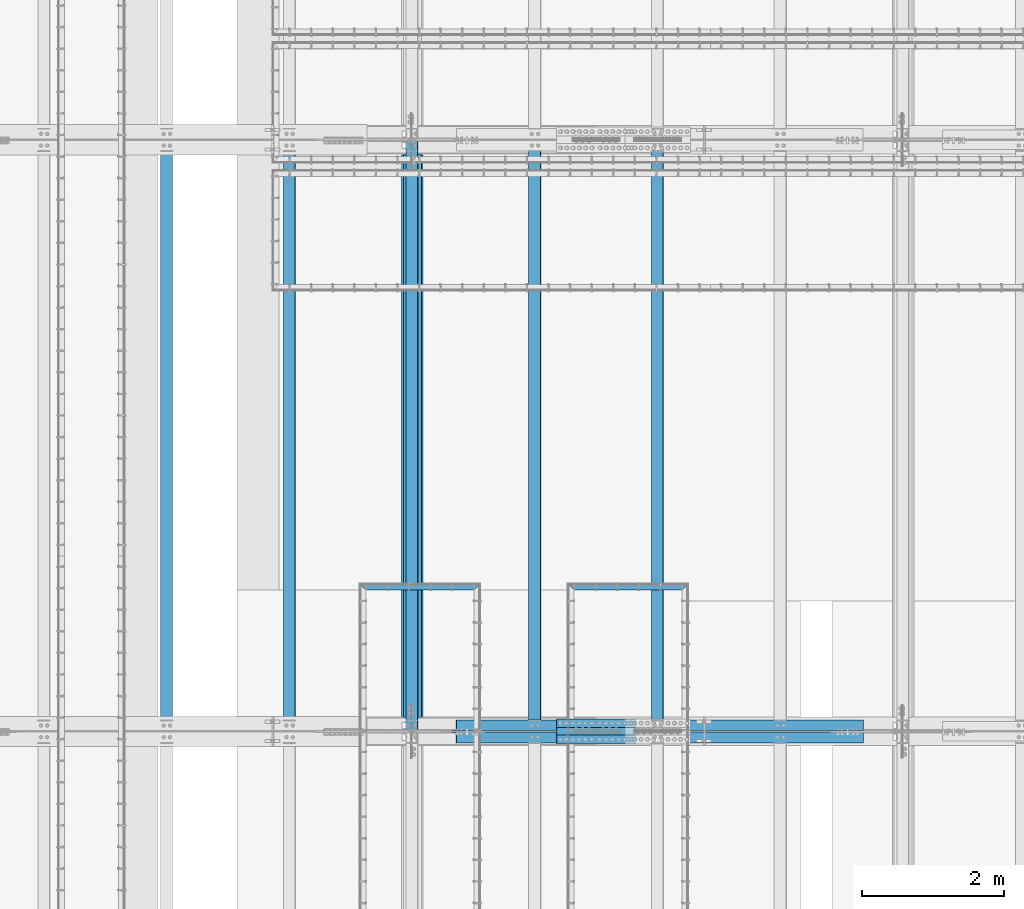
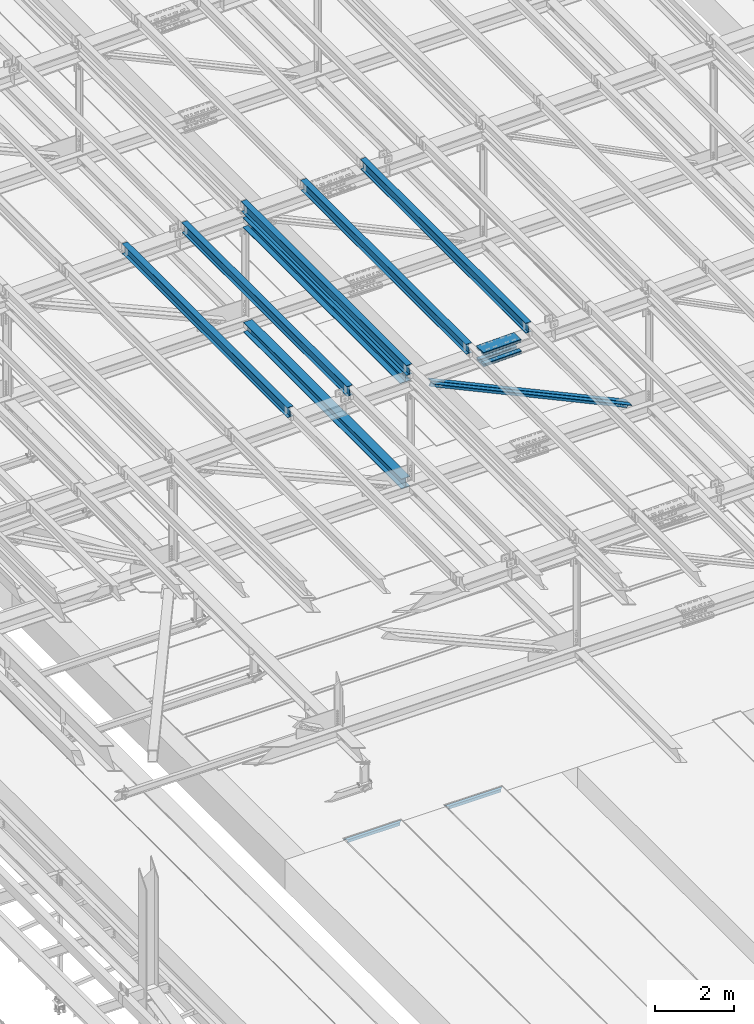
# One storey, part 1844 of 3843: 15 beams, 2 members, 12 elements without a shape of their own.
"""IFC2X3 building model written with IfcOpenShell, lengths in millimetres."""

import ifcopenshell
import ifcopenshell.guid

model = None  # the IFC model being written
_history = None  # IfcOwnerHistory: only IFC2X3 demands one
_inside = {}  # id of a spatial element -> (the spatial element, [elements in it])
_under = {}  # id of a project, library or spatial element -> (it, [spatial elements below it])
_declared = {}  # id of a project -> (the project, [libraries it declares])
_typed = {}  # id of a type object -> (the type object, [elements of that type])
_made_of = {}  # id of a material, layer set ... -> (it, [elements and type objects made of it])


def new_model(schema):
    """Start an empty IFC model of exactly this schema.

    Asked for "IFC4X3", IfcOpenShell would pick the latest addendum, in which some entities
    have other attributes; the version numbers below select the first issue.
    IFC2X3 requires an IfcOwnerHistory on every rooted entity: one is made here for all.
    """
    global model, _history
    if schema == "IFC4X3":
        model = ifcopenshell.file(schema_version=(4, 3, 0, 0))
    else:
        model = ifcopenshell.file(schema=schema)
    _inside.clear()
    _under.clear()
    _declared.clear()
    _typed.clear()
    _made_of.clear()
    _history = None
    if model.schema == "IFC2X3":
        org = make("IfcOrganization", Name="unknown")
        user = make(
            "IfcPersonAndOrganization",
            ThePerson=make("IfcPerson", FamilyName="unknown"),
            TheOrganization=org,
        )
        app = make(
            "IfcApplication",
            ApplicationDeveloper=org,
            Version="unknown",
            ApplicationFullName="unknown",
            ApplicationIdentifier="unknown",
        )
        _history = make(
            "IfcOwnerHistory",
            OwningUser=user,
            OwningApplication=app,
            ChangeAction="ADDED",
            CreationDate=0,
        )
    return model


def make(cls, **values):
    """One entity of the class cls with the attributes given. An attribute that is None is left unset."""
    return model.create_entity(
        cls, **{name: value for name, value in values.items() if value is not None}
    )


def rooted(cls, **values):
    """An entity with a GlobalId (a new one), such as an element, a storey or a relation."""
    return make(cls, GlobalId=ifcopenshell.guid.new(), OwnerHistory=_history, **values)


def si_unit(unit_type, name, prefix=None):
    """IfcSIUnit, for example si_unit("LENGTHUNIT", "METRE", prefix="MILLI")."""
    return make("IfcSIUnit", UnitType=unit_type, Prefix=prefix, Name=name)


def assignment(units):
    """IfcUnitAssignment: the units of a project."""
    return None if units is None else make("IfcUnitAssignment", Units=units)


def point(xyz):
    """IfcCartesianPoint."""
    return None if xyz is None else make("IfcCartesianPoint", Coordinates=xyz)


def direction(xyz):
    """IfcDirection."""
    return None if xyz is None else make("IfcDirection", DirectionRatios=xyz)


def frame(location, z_axis=None, x_axis=None):
    """IfcAxis2Placement3D, a coordinate frame: its origin and axes. An axis left out is left unset."""
    return make(
        "IfcAxis2Placement3D",
        Location=point(location),
        Axis=direction(z_axis),
        RefDirection=direction(x_axis),
    )


def origin_with_axes():
    """The frame at (0, 0, 0) with the z axis (0, 0, 1) and the x axis (1, 0, 0) written out."""
    return frame((0.0, 0.0, 0.0), z_axis=(0.0, 0.0, 1.0), x_axis=(1.0, 0.0, 0.0))


def place(relative_to, where):
    """IfcLocalPlacement: puts the frame where relative to a parent placement (None: the world)."""
    return make(
        "IfcLocalPlacement", PlacementRelTo=relative_to, RelativePlacement=where
    )


def context(
    kind, dimensions, precision=None, world=None, true_north=None, identifier=None
):
    """IfcGeometricRepresentationContext, for example the 3D "Model" context."""
    return make(
        "IfcGeometricRepresentationContext",
        ContextIdentifier=identifier,
        ContextType=kind,
        CoordinateSpaceDimension=dimensions,
        Precision=precision,
        WorldCoordinateSystem=world,
        TrueNorth=true_north,
    )


def subcontext(parent, identifier, kind, view, scale=None):
    """IfcGeometricRepresentationSubContext, for example "Body" below "Model"."""
    return make(
        "IfcGeometricRepresentationSubContext",
        ContextIdentifier=identifier,
        ContextType=kind,
        ParentContext=parent,
        TargetScale=scale,
        TargetView=view,
    )


def project(units=None, contexts=None):
    """IfcProject with its units and contexts."""
    return rooted(
        "IfcProject",
        Name="project",
        RepresentationContexts=contexts,
        UnitsInContext=assignment(units),
    )


def spatial(cls, under=None, at=None, **own):
    """A site, building, storey or space (cls), placed at a placement, below another one or the project."""
    s = rooted(cls, ObjectPlacement=at, **own)
    if under is not None:
        _under.setdefault(under.id(), (under, []))[1].append(s)
    return s


def faces_of(points, faces, orient=None, outer=None):
    """IfcFace entities. A face is a list of loops; a loop is a list of indices into points, from 0.

    orient and outer hold one flag for each loop. By default every Orientation is true, the
    first loop of a face is its IfcFaceOuterBound and the others are IfcFaceBound.
    """
    made = []
    for i, loops in enumerate(faces):
        bounds = []
        for j, loop in enumerate(loops):
            is_outer = j == 0 if outer is None else outer[i][j]
            bounds.append(
                make(
                    "IfcFaceOuterBound" if is_outer else "IfcFaceBound",
                    Bound=make("IfcPolyLoop", Polygon=[points[k] for k in loop]),
                    Orientation=True if orient is None else orient[i][j],
                )
            )
        made.append(make("IfcFace", Bounds=bounds))
    return made


def faceted_brep(points, faces, orient=None, outer=None, voids=None):
    """IfcFacetedBrep: a solid bounded by flat faces; with voids (closed shells), ...WithVoids."""
    shared = [point(p) for p in points]
    hull = make("IfcClosedShell", CfsFaces=faces_of(shared, faces, orient, outer))
    if voids is None:
        return make("IfcFacetedBrep", Outer=hull)
    return make(
        "IfcFacetedBrepWithVoids",
        Outer=hull,
        Voids=[
            make(cls, CfsFaces=faces_of(shared, fs, o, b)) for cls, fs, o, b in voids
        ],
    )


def shape(context_of_items, identifier, shape_type, items):
    """IfcShapeRepresentation: the items that make up one representation, for example the "Body"."""
    return make(
        "IfcShapeRepresentation",
        ContextOfItems=context_of_items,
        RepresentationIdentifier=identifier,
        RepresentationType=shape_type,
        Items=items,
    )


def material(Name=None, Category=None):
    """IfcMaterial."""
    return make("IfcMaterial", Name=Name, Category=Category)


def made_of(thing, what):
    """Note that an element or type object is made of a material, layer set ...; save() writes the relation."""
    if what is not None:
        _made_of.setdefault(what.id(), (what, []))[1].append(thing)
    return thing


def type_object(cls, material=None, **own):
    """A type object (cls), such as IfcWallType, which elements share."""
    return made_of(rooted(cls, **own), material)


def element(
    cls,
    number,
    at=None,
    inside=None,
    cuts=None,
    type_object=None,
    material=None,
    context=None,
    identifier="Body",
    shape_type=None,
    held_by="IfcProductDefinitionShape",
    body=None,
    shapes=None,
    **own,
):
    """One element of the class cls, such as IfcWall. Its Tag is "e" and its number.

    at: its placement. inside: the storey or other place that contains it. cuts: it is an
    opening in that element (IfcRelVoidsElement). A single representation is given by context,
    identifier, shape_type and body (its items); several are given by shapes. held_by: the class
    of the entity that holds the representations. save() writes the other relations.
    """
    e = rooted(cls, Tag="e%d" % number, ObjectPlacement=at, **own)
    if body is not None:
        shapes = [shape(context, identifier, shape_type, body)]
    if shapes is not None:
        e.Representation = make(held_by, Representations=shapes)
    if inside is not None:
        _inside.setdefault(inside.id(), (inside, []))[1].append(e)
    if cuts is not None:
        rooted(
            "IfcRelVoidsElement", RelatingBuildingElement=cuts, RelatedOpeningElement=e
        )
    if type_object is not None:
        _typed.setdefault(type_object.id(), (type_object, []))[1].append(e)
    return made_of(e, material)


def aggregate(whole, parts):
    """IfcRelAggregates: a whole, such as a stair, and the parts it consists of."""
    return rooted("IfcRelAggregates", RelatingObject=whole, RelatedObjects=parts)


def save(model, path):
    """Write the relations noted so far, then the file.

    IfcRelAggregates (storeys below a building ...), IfcRelContainedInSpatialStructure (elements
    in a storey), IfcRelDefinesByType, IfcRelAssociatesMaterial and IfcRelDeclares: one each for
    every whole, place, type object, material and project.
    """
    for whole, parts in _under.values():
        aggregate(whole, parts)
    for where, things in _inside.values():
        rooted(
            "IfcRelContainedInSpatialStructure",
            RelatedElements=things,
            RelatingStructure=where,
        )
    for kind, things in _typed.values():
        rooted("IfcRelDefinesByType", RelatedObjects=things, RelatingType=kind)
    for what, things in _made_of.values():
        rooted("IfcRelAssociatesMaterial", RelatedObjects=things, RelatingMaterial=what)
    for by, libraries in _declared.values():
        rooted("IfcRelDeclares", RelatingContext=by, RelatedDefinitions=libraries)
    model.write(path)


model = new_model("IFC2X3")

# Units and contexts
model_context = context("Model", 3, precision=1e-05, world=origin_with_axes())
body_context = subcontext(model_context, "Body", "Model", "MODEL_VIEW")
ifc_project = project(units=[si_unit("LENGTHUNIT", "METRE", prefix="MILLI"), si_unit("AREAUNIT", "SQUARE_METRE"), si_unit("VOLUMEUNIT", "CUBIC_METRE"), si_unit("MASSUNIT", "GRAM", prefix="KILO"), si_unit("TIMEUNIT", "SECOND"), si_unit("PLANEANGLEUNIT", "RADIAN"), si_unit("SOLIDANGLEUNIT", "STERADIAN"), si_unit("THERMODYNAMICTEMPERATUREUNIT", "DEGREE_CELSIUS"), si_unit("LUMINOUSINTENSITYUNIT", "LUMEN")], contexts=[model_context])

# Site, building, storey
site_placement = place(None, origin_with_axes())
site = spatial("IfcSite", under=ifc_project, at=site_placement, CompositionType="ELEMENT")
building_placement = place(site_placement, origin_with_axes())
building = spatial("IfcBuilding", under=site, at=building_placement, Name="Undefined", CompositionType="ELEMENT")
storey_placement = place(building_placement, origin_with_axes())
storey = spatial("IfcBuildingStorey", under=building, at=storey_placement, Name="Undefined", CompositionType="ELEMENT", Elevation=0.0)

# Assembly, beam
assembly_1_placement = place(storey_placement, origin_with_axes())
assembly_1 = element("IfcElementAssembly", 1, at=assembly_1_placement, inside=storey, Name="EMBED_ANGLE", AssemblyPlace="NOTDEFINED", PredefinedType="RIGID_FRAME")
ifc_material_1 = material(Name="STEEL/A36")
beam_type_1 = type_object("IfcBeamType", Name="L3-1/2X3-1/2X5/16", PredefinedType="NOTDEFINED")
beam_1_placement = place(assembly_1_placement, frame((51194.4619996658, 52597.049609375, 30410.15), z_axis=(0.0, 0.0, -1.0), x_axis=(1.0, 0.0, 0.0)))
beam_1 = element("IfcBeam", 2, at=beam_1_placement, type_object=beam_type_1, material=ifc_material_1, Name="EMBED_ANGLE", ObjectType="L3-1/2X3-1/2X5/16", context=body_context, shape_type="Brep", body=[
    faceted_brep([(88.8999999971129, 44.4500000000007, -44.4499999999971), (88.8999999965163, 44.4499999999971, 44.4500000000007), (1612.83655761749, 44.4499999999971, 44.4500000000007), (1612.83653598122, 44.4500000000007, -44.4500000082771), (80.9624999965163, 36.5124999999971, 44.4500000000007), (1620.77405488424, 36.5124999999971, 44.4500000000007), (80.9624999971129, 36.5125000000007, -36.5124999999971), (1620.77403605285, 36.5125000000007, -36.5125000083208), (3.63797880709171e-12, -44.4499999999971, -36.5125000000007), (1701.73652700515, -44.4500000000044, -36.5125000000007), (3.63797880709171e-12, -44.4499999999971, -44.4500000000007), (1701.73652700515, -44.4500000000044, -44.4500000000007)], [[[0, 1, 2, 3]], [[1, 4, 5, 2]], [[4, 6, 7, 5]], [[6, 8, 9, 7]], [[8, 10, 11, 9]], [[10, 0, 3, 11]], [[5, 7, 9, 11, 3, 2]], [[10, 8, 6, 4, 1, 0]]]),
])
aggregate(assembly_1, [beam_1])

assembly_2_placement = place(storey_placement, origin_with_axes())
assembly_2 = element("IfcElementAssembly", 3, at=assembly_2_placement, inside=storey, Name="EMBED_ANGLE", AssemblyPlace="NOTDEFINED", PredefinedType="RIGID_FRAME")
beam_2_placement = place(assembly_2_placement, frame((48254.4116363981, 52597.0501953125, 30410.15), z_axis=(0.0, 0.0, -1.0), x_axis=(1.0, 0.0, 0.0)))
beam_2 = element("IfcBeam", 4, at=beam_2_placement, type_object=beam_type_1, material=ifc_material_1, Name="EMBED_ANGLE", ObjectType="L3-1/2X3-1/2X5/16", context=body_context, shape_type="Brep", body=[
    faceted_brep([(88.9311323255606, 44.4499999999971, -44.4500000000007), (88.9311323255606, 44.4499999999971, 44.4500000000007), (1612.90043651201, 44.4499999999971, 44.4500000000007), (1612.90046664741, 44.4500000000044, -44.4500000000007), (80.9936701268525, 36.5125000000044, 44.4500000000007), (1620.83796395906, 36.5124999999971, 44.4500000000007), (80.9936701268525, 36.5125000000044, -36.5125000000007), (1620.83791496794, 36.5125000000007, -36.5125000083208), (0.0315557000430999, -44.4499999999971, -36.5125000000007), (1701.80043653794, -44.4500000000044, -36.5125000000007), (0.0315557000430999, -44.4499999999971, -44.4500000000007), (1701.80043653794, -44.4500000000044, -44.4500000000007)], [[[0, 1, 2, 3]], [[1, 4, 5, 2]], [[4, 6, 7, 5]], [[6, 8, 9, 7]], [[8, 10, 11, 9]], [[10, 0, 3, 11]], [[5, 7, 9, 11, 3, 2]], [[10, 8, 6, 4, 1, 0]]]),
])
aggregate(assembly_2, [beam_2])

assembly_3_placement = place(storey_placement, origin_with_axes())
assembly_3 = element("IfcElementAssembly", 5, at=assembly_3_placement, inside=storey, Name="BEAM", AssemblyPlace="NOTDEFINED", PredefinedType="RIGID_FRAME")
ifc_material_2 = material(Name="STEEL/A992")
beam_type_2 = type_object("IfcBeamType", Name="W12X26", PredefinedType="NOTDEFINED")
beam_3_placement = place(assembly_3_placement, frame((48993.3092623529, 50558.6724173019, 45897.8561118274), z_axis=(-0.0211520983397932, -0.000177294999935839, 0.999776253619932), x_axis=(0.0, 0.999999984276149, 0.000177335000048955)))
beam_3 = element("IfcBeam", 6, at=beam_3_placement, type_object=beam_type_2, material=ifc_material_2, Name="BEAM", ObjectType="W12X26", context=body_context, shape_type="Brep", body=[
    faceted_brep([(12.6996905321212, 82.5499999995955, -155.575000000317), (12.7013792701255, 82.5499999996027, -146.050000000287), (8343.90151027715, 82.5499999993699, -146.049999989416), (8343.89983598545, 82.549999998897, -155.574999980701), (12.7016770060582, 3.17499999975553, -146.050000000316), (8343.90180801308, 3.1749999995227, -146.049999989453), (12.7534649713998, 3.17500000022119, 146.050000000367), (8343.95359597841, 3.17499999998836, 146.05000001123), (12.7531672354671, 82.5500000000684, 146.050000000396), (8343.95329824248, 82.5499999998356, 146.050000011266), (12.7548559734569, 82.5500000000902, 155.575000000419), (8343.95498698048, 82.5499999998501, 155.575000011282), (12.7554752642027, -82.5499999995882, 155.575000000346), (8343.95560627122, -82.549999999821, 155.575000011217), (12.7537865262057, -82.5499999996027, 146.050000000323), (8343.95391753322, -82.5499999998356, 146.050000011201), (12.753488790273, -3.17499999975553, 146.050000000359), (8343.95361979728, -3.17499999998836, 146.05000001123), (12.7017008249313, -3.17500000022119, -146.050000000323), (8343.90183183196, -3.1750000004613, -146.049999989453), (12.701998560864, -82.5500000000684, -146.050000000359), (8343.90212956789, -82.5500000003085, -146.049999989482), (12.7003098228597, -82.5500000000902, -155.575000000375), (8343.90039994755, -82.5500000008615, -155.574999972298)], [[[0, 1, 2, 3]], [[1, 4, 5, 2]], [[4, 6, 7, 5]], [[6, 8, 9, 7]], [[8, 10, 11, 9]], [[10, 12, 13, 11]], [[12, 14, 15, 13]], [[14, 16, 17, 15]], [[16, 18, 19, 17]], [[18, 20, 21, 19]], [[20, 22, 23, 21]], [[22, 0, 3, 23]], [[5, 7, 9, 11, 13, 15, 17, 19, 21, 23, 3, 2]], [[22, 20, 18, 16, 14, 12, 10, 8, 6, 4, 1, 0]]]),
])
aggregate(assembly_3, [beam_3])

assembly_4_placement = place(storey_placement, origin_with_axes())
assembly_4 = element("IfcElementAssembly", 7, at=assembly_4_placement, inside=storey, Name="BEAM", AssemblyPlace="NOTDEFINED", PredefinedType="RIGID_FRAME")
beam_4_placement = place(assembly_4_placement, frame((52460.4092623271, 50558.6647243622, 45983.0414342273), z_axis=(-0.0211520975512395, -0.000226743999919563, 0.999776243644717), x_axis=(-9.99999662068761e-10, 0.999999974282241, 0.000226794000063866)))
beam_4 = element("IfcBeam", 8, at=beam_4_placement, type_object=beam_type_2, material=ifc_material_2, Name="BEAM", ObjectType="W12X26", context=body_context, shape_type="Brep", body=[
    faceted_brep([(12.6996044540356, 82.5499999995518, -155.574999999466), (12.7017641838465, 82.5499999995591, -146.049999999501), (8343.90198525623, 82.5500000010506, -146.050000014387), (8343.89983598545, 82.549999998897, -155.574999980701), (12.7021448802989, 3.17499999971915, -146.049999999537), (8343.90235909428, 3.17499997315463, -146.050000001458), (12.7683765945112, 3.17500000016298, 146.049999999545), (8343.96859080851, 3.17499997359846, 146.049999997624), (12.7679958980589, 82.5500000000175, 146.049999999581), (8343.96821011205, 82.5499999734529, 146.04999999766), (12.7701556278626, 82.5500000000247, 155.574999999546), (8343.97036984185, 82.5499999734675, 155.574999997625), (12.7709474764924, -82.5499999996464, 155.57499999948), (8343.97116169048, -82.5500000262182, 155.57499999756), (12.7687877466888, -82.5499999996682, 146.049999999508), (8343.96900196068, -82.5500000262255, 146.049999997587), (12.7684070502291, -3.17499999982101, 146.049999999545), (8343.96862126421, -3.17500002638553, 146.049999997624), (12.7021753360168, -3.17500000027212, -146.049999999545), (8343.90238955, -3.17500002683664, -146.050000001458), (12.7025560324764, -82.550000000112, -146.049999999566), (8343.90277024645, -82.5500000266838, -146.050000001494), (12.7004394891774, -82.5499999997337, -155.575000000586), (8343.90056667817, -82.5500000221655, -155.574999973665)], [[[0, 1, 2, 3]], [[1, 4, 5, 2]], [[4, 6, 7, 5]], [[6, 8, 9, 7]], [[8, 10, 11, 9]], [[10, 12, 13, 11]], [[12, 14, 15, 13]], [[14, 16, 17, 15]], [[16, 18, 19, 17]], [[18, 20, 21, 19]], [[20, 22, 23, 21]], [[22, 0, 3, 23]], [[5, 7, 9, 11, 13, 15, 17, 19, 21, 23, 3, 2]], [[22, 20, 18, 16, 14, 12, 10, 8, 6, 4, 1, 0]]]),
])
aggregate(assembly_4, [beam_4])

assembly_5_placement = place(storey_placement, origin_with_axes())
assembly_5 = element("IfcElementAssembly", 9, at=assembly_5_placement, inside=storey, Name="BEAM", AssemblyPlace="NOTDEFINED", PredefinedType="RIGID_FRAME")
beam_5_placement = place(assembly_5_placement, frame((50726.8592622892, 50558.6675876924, 45940.7253662471), z_axis=(-0.0211520984662202, -0.000208338999917032, 0.999776247630107), x_axis=(-9.99999666074426e-10, 0.999999978287846, 0.000208385000060057)))
beam_5 = element("IfcBeam", 10, at=beam_5_placement, type_object=beam_type_2, material=ifc_material_2, Name="BEAM", ObjectType="W12X26", context=body_context, shape_type="Brep", body=[
    faceted_brep([(12.6996044540356, 82.5499999995518, -155.574999999466), (12.7016209808717, 82.5499999996027, -146.050000000381), (8343.90180188082, 82.5499999734311, -146.050000020798), (8343.89983598545, 82.549999998897, -155.574999980701), (12.7019707694562, 3.17499999974825, -146.050000000214), (8343.90215166939, 3.17499997357663, -146.05000002063), (12.7628264154555, 3.17500000014843, 146.050000000134), (8343.96300731539, 3.17499997396953, 146.049999979718), (12.7624766268782, 82.5500000000029, 146.049999999967), (8343.96265752682, 82.5499999738167, 146.049999979565), (12.7644610501229, 82.5500000000102, 155.574999999975), (8343.96464195006, 82.5499999738386, 155.574999979566), (12.7651886103631, -82.5499999996682, 155.575000000325), (8343.9653695103, -82.5500000258544, 155.574999979915), (12.7632041871257, -82.54999999969, 146.050000000309), (8343.96338508706, -82.5500000258617, 146.049999979899), (12.7628543985484, -3.17499999983556, 146.050000000148), (8343.96303529849, -3.17500002601446, 146.049999979732), (12.7019987525346, -3.17500000022847, -146.050000000199), (8343.90217965248, -3.17500002640736, -146.050000020608), (12.7023485411264, -82.5500000000829, -146.050000000032), (8343.90252944106, -82.5500000262618, -146.050000020448), (12.7003641178817, -82.5500000000975, -155.575000000048), (8343.90056667817, -82.5500000221655, -155.574999973665)], [[[0, 1, 2, 3]], [[1, 4, 5, 2]], [[4, 6, 7, 5]], [[6, 8, 9, 7]], [[8, 10, 11, 9]], [[10, 12, 13, 11]], [[12, 14, 15, 13]], [[14, 16, 17, 15]], [[16, 18, 19, 17]], [[18, 20, 21, 19]], [[20, 22, 23, 21]], [[22, 0, 3, 23]], [[5, 7, 9, 11, 13, 15, 17, 19, 21, 23, 3, 2]], [[22, 20, 18, 16, 14, 12, 10, 8, 6, 4, 1, 0]]]),
])
aggregate(assembly_5, [beam_5])

assembly_6_placement = place(storey_placement, origin_with_axes())
assembly_6 = element("IfcElementAssembly", 11, at=assembly_6_placement, inside=storey, Name="BEAM", AssemblyPlace="NOTDEFINED", PredefinedType="RIGID_FRAME")
beam_6_placement = place(assembly_6_placement, frame((47259.7592623332, 50558.6758431992, 45854.4241167561), z_axis=(-0.021152098262195, -0.000155274000040663, 0.999776257284144), x_axis=(-9.99999675726156e-10, 0.999999987939557, 0.000155308999990748)))
beam_6 = element("IfcBeam", 12, at=beam_6_placement, type_object=beam_type_2, material=ifc_material_2, Name="BEAM", ObjectType="W12X26", context=body_context, shape_type="Brep", body=[
    faceted_brep([(12.6996905321212, 82.5499999995955, -155.575000000317), (12.7012080434215, 82.5499999995009, -146.050000000221), (8343.90130846984, 82.5499999734457, -146.050000026451), (8343.89983598545, 82.549999998897, -155.574999980701), (12.7014687199189, 3.17499999962456, -146.050000000032), (8343.90156914633, 3.17499997357663, -146.050000026262), (12.7468243342591, 3.17500000027212, 146.04999999993), (8343.94692476067, 3.17499997420964, 146.049999973708), (12.7465636577545, 82.5500000001484, 146.049999999734), (8343.94666408416, 82.5499999740787, 146.049999973504), (12.7480426451802, 82.550000000163, 155.574999999728), (8343.9481430716, 82.5499999741078, 155.574999973513), (12.7485848522992, -82.5499999995736, 155.57500000015), (8343.94868527871, -82.5500000256288, 155.57499997392), (12.7471058648807, -82.5499999995955, 146.050000000148), (8343.94720629129, -82.5500000256434, 146.049999973926), (12.746845188376, -3.17499999971915, 146.049999999945), (8343.94694561479, -3.17500002577435, 146.049999973722), (12.7014895740504, -3.17500000035216, -146.050000000017), (8343.90159000046, -3.17500002642191, -146.05000002624), (12.7017502505478, -82.5500000002357, -146.049999999814), (8343.90185067696, -82.5500000262909, -146.050000026036), (12.7003098228597, -82.5500000000902, -155.575000000375), (8343.90039994755, -82.5500000008615, -155.574999972298)], [[[0, 1, 2, 3]], [[1, 4, 5, 2]], [[4, 6, 7, 5]], [[6, 8, 9, 7]], [[8, 10, 11, 9]], [[10, 12, 13, 11]], [[12, 14, 15, 13]], [[14, 16, 17, 15]], [[16, 18, 19, 17]], [[18, 20, 21, 19]], [[20, 22, 23, 21]], [[22, 0, 3, 23]], [[5, 7, 9, 11, 13, 15, 17, 19, 21, 23, 3, 2]], [[22, 20, 18, 16, 14, 12, 10, 8, 6, 4, 1, 0]]]),
])
aggregate(assembly_6, [beam_6])

assembly_7_placement = place(storey_placement, origin_with_axes())
assembly_7 = element("IfcElementAssembly", 13, at=assembly_7_placement, inside=storey, Name="BEAM", AssemblyPlace="NOTDEFINED", PredefinedType="RIGID_FRAME")
beam_7_placement = place(assembly_7_placement, frame((45526.2092623097, 50558.6801162159, 45810.4141370448), z_axis=(-0.0211520981801223, -0.000127808000019286, 0.999776261174316), x_axis=(0.0, 0.999999991828851, 0.000127836999978207)))
beam_7 = element("IfcBeam", 14, at=beam_7_placement, type_object=beam_type_2, material=ifc_material_2, Name="BEAM", ObjectType="W12X26", context=body_context, shape_type="Brep", body=[
    faceted_brep([(12.6997768804213, 82.5500000002576, -155.574999999757), (12.7009942553632, 82.550000000243, -146.049999999792), (8343.901062335, 82.5500000008687, -146.050000029609), (8343.89983598545, 82.549999998897, -155.574999980701), (12.7012088868796, 3.17500000036671, -146.049999999559), (8343.90127696652, 3.17500000099972, -146.050000029383), (12.7385417186015, 3.17499999959546, 146.049999999457), (8343.93860979824, 3.17500000022119, 146.04999996964), (12.7383270870778, 82.5499999994572, 146.049999999232), (8343.93839516673, 82.5500000000902, 146.049999969422), (12.7395444620342, 82.5499999994354, 155.574999999197), (8343.93961254167, 82.5500000000684, 155.574999969387), (12.7399908955849, -82.5500000002867, 155.574999999662), (8343.94005897523, -82.5499999996537, 155.574999969846), (12.738773520643, -82.5500000002648, 146.049999999697), (8343.93884160028, -82.5499999996318, 146.04999996988), (12.7385588891193, -3.17500000039581, 146.049999999479), (8343.93862696876, -3.1749999997628, 146.049999969655), (12.7012260574047, -3.17499999961728, -146.049999999545), (8343.90129413704, -3.17499999899155, -146.050000029361), (12.7014406889211, -82.549999999479, -146.049999999326), (8343.90150876855, -82.5499999988533, -146.050000029136), (12.7002233139719, -82.5499999994645, -155.574999999291), (8343.90031498027, -82.5500000207103, -155.574999994577)], [[[0, 1, 2, 3]], [[1, 4, 5, 2]], [[4, 6, 7, 5]], [[6, 8, 9, 7]], [[8, 10, 11, 9]], [[10, 12, 13, 11]], [[12, 14, 15, 13]], [[14, 16, 17, 15]], [[16, 18, 19, 17]], [[18, 20, 21, 19]], [[20, 22, 23, 21]], [[22, 0, 3, 23]], [[5, 7, 9, 11, 13, 15, 17, 19, 21, 23, 3, 2]], [[22, 20, 18, 16, 14, 12, 10, 8, 6, 4, 1, 0]]]),
])
aggregate(assembly_7, [beam_7])

# Assembly, beams
assembly_8_placement = place(storey_placement, origin_with_axes())
assembly_8 = element("IfcElementAssembly", 15, at=assembly_8_placement, inside=storey, Name="BEAM", AssemblyPlace="NOTDEFINED", PredefinedType="RIGID_FRAME")
ifc_material_3 = material(Name="STEEL/A572-50")
beam_type_3 = type_object("IfcBeamType", PredefinedType="NOTDEFINED")
beam_8_placement = place(assembly_8_placement, frame((51036.3171595471, 50673.0, 45743.474226814), z_axis=(0.0, -1.0, 0.0), x_axis=(0.999702292911448, 0.0, 0.0243992939978356)))
beam_8 = element("IfcBeam", 16, at=beam_8_placement, type_object=beam_type_3, material=ifc_material_3, Name="PLATE", context=body_context, shape_type="Brep", body=[
    faceted_brep([(-4.36557456851006e-11, 12.7000000000116, -63.5), (-4.36557456851006e-11, 12.7000000000116, 63.5), (1104.90000001677, 12.7000000017251, 63.5), (1104.90000001677, 12.7000000017251, -63.5), (1.45519152283669e-11, -12.700000000008, 63.5), (1104.90000001682, -12.6999999982909, 63.5), (1.45519152283669e-11, -12.700000000008, -63.5), (1104.90000001682, -12.6999999982909, -63.5)], [[[0, 1, 2, 3]], [[1, 4, 5, 2]], [[4, 6, 7, 5]], [[6, 0, 3, 7]], [[5, 7, 3, 2]], [[6, 4, 1, 0]]]),
])
beam_9_placement = place(assembly_8_placement, frame((51043.5215263733, 50673.0, 45448.2926555707), z_axis=(0.0, -1.0, 0.0), x_axis=(0.999702292911448, 0.0, 0.0243992939978356)))
beam_9 = element("IfcBeam", 17, at=beam_9_placement, type_object=beam_type_3, material=ifc_material_3, Name="PLATE", context=body_context, shape_type="Brep", body=[
    faceted_brep([(-4.36557456851006e-11, 12.7000000000116, -63.5), (-4.36557456851006e-11, 12.7000000000116, 63.5), (1104.90000001677, 12.7000000017251, 63.5), (1104.90000001677, 12.7000000017251, -63.5), (1.45519152283669e-11, -12.700000000008, 63.5), (1104.90000001682, -12.6999999982909, 63.5), (1.45519152283669e-11, -12.700000000008, -63.5), (1104.90000001682, -12.6999999982909, -63.5)], [[[0, 1, 2, 3]], [[1, 4, 5, 2]], [[4, 6, 7, 5]], [[6, 0, 3, 7]], [[5, 7, 3, 2]], [[6, 4, 1, 0]]]),
])
beam_10_placement = place(assembly_8_placement, frame((51036.3171595471, 50444.4, 45743.474226814), z_axis=(0.0, -1.0, 0.0), x_axis=(0.999702292911448, 0.0, 0.0243992939978356)))
beam_10 = element("IfcBeam", 18, at=beam_10_placement, type_object=beam_type_3, material=ifc_material_3, Name="PLATE", context=body_context, shape_type="Brep", body=[
    faceted_brep([(-4.36557456851006e-11, 12.7000000000116, -63.5), (-4.36557456851006e-11, 12.7000000000116, 63.5), (1104.90000001677, 12.7000000017251, 63.5), (1104.90000001677, 12.7000000017251, -63.5), (1.45519152283669e-11, -12.700000000008, 63.5), (1104.90000001682, -12.6999999982909, 63.5), (1.45519152283669e-11, -12.700000000008, -63.5), (1104.90000001682, -12.6999999982909, -63.5)], [[[0, 1, 2, 3]], [[1, 4, 5, 2]], [[4, 6, 7, 5]], [[6, 0, 3, 7]], [[5, 7, 3, 2]], [[6, 4, 1, 0]]]),
])
beam_11_placement = place(assembly_8_placement, frame((51043.5215263733, 50444.4, 45448.2926555707), z_axis=(0.0, -1.0, 0.0), x_axis=(0.999702292911448, 0.0, 0.0243992939978356)))
beam_11 = element("IfcBeam", 19, at=beam_11_placement, type_object=beam_type_3, material=ifc_material_3, Name="PLATE", context=body_context, shape_type="Brep", body=[
    faceted_brep([(-4.36557456851006e-11, 12.7000000000116, -63.5), (-4.36557456851006e-11, 12.7000000000116, 63.5), (1104.90000001677, 12.7000000017251, 63.5), (1104.90000001677, 12.7000000017251, -63.5), (1.45519152283669e-11, -12.700000000008, 63.5), (1104.90000001682, -12.6999999982909, 63.5), (1.45519152283669e-11, -12.700000000008, -63.5), (1104.90000001682, -12.6999999982909, -63.5)], [[[0, 1, 2, 3]], [[1, 4, 5, 2]], [[4, 6, 7, 5]], [[6, 0, 3, 7]], [[5, 7, 3, 2]], [[6, 4, 1, 0]]]),
])
beam_type_4 = type_object("IfcBeamType", PredefinedType="NOTDEFINED")
beam_12_placement = place(assembly_8_placement, frame((52139.3756997659, 50558.7, 45832.4050004519), z_axis=(0.0, -1.0, 0.0), x_axis=(-0.999702292911448, 0.0, -0.0243992939978336)))
beam_12 = element("IfcBeam", 20, at=beam_12_placement, type_object=beam_type_4, material=ifc_material_3, Name="PLATE", context=body_context, shape_type="Brep", body=[
    faceted_brep([(-1.45519152283669e-11, 12.7000000000025, -177.800000000003), (-1.45519152283669e-11, 12.7000000000025, 177.800000000003), (1104.90000001682, 12.7000000017051, 177.800000000003), (1104.90000001682, 12.7000000017051, -177.800000000003), (4.36557456851006e-11, -12.7000000000171, 177.800000000003), (1104.90000001686, -12.6999999983072, 177.800000000003), (4.36557456851006e-11, -12.7000000000171, -177.800000000003), (1104.90000001686, -12.6999999983072, -177.800000000003)], [[[0, 1, 2, 3]], [[1, 4, 5, 2]], [[4, 6, 7, 5]], [[6, 0, 3, 7]], [[5, 7, 3, 2]], [[6, 4, 1, 0]]]),
])
beam_13_placement = place(assembly_8_placement, frame((52149.6059751846, 50558.7, 45413.3574347492), z_axis=(0.0, -1.0, 0.0), x_axis=(-0.999702292911448, 0.0, -0.0243992939978336)))
beam_13 = element("IfcBeam", 21, at=beam_13_placement, type_object=beam_type_4, material=ifc_material_3, Name="PLATE", context=body_context, shape_type="Brep", body=[
    faceted_brep([(-1.45519152283669e-11, 12.7000000000025, -177.800000000003), (-1.45519152283669e-11, 12.7000000000025, 177.800000000003), (1104.90000001682, 12.7000000017051, 177.800000000003), (1104.90000001682, 12.7000000017051, -177.800000000003), (4.36557456851006e-11, -12.7000000000171, 177.800000000003), (1104.90000001686, -12.6999999983072, 177.800000000003), (4.36557456851006e-11, -12.7000000000171, -177.800000000003), (1104.90000001686, -12.6999999983072, -177.800000000003)], [[[0, 1, 2, 3]], [[1, 4, 5, 2]], [[4, 6, 7, 5]], [[6, 0, 3, 7]], [[5, 7, 3, 2]], [[6, 4, 1, 0]]]),
])
aggregate(assembly_8, [beam_8, beam_9, beam_10, beam_11, beam_12, beam_13])

# Assembly, member
assembly_9_placement = place(storey_placement, origin_with_axes())
assembly_9 = element("IfcElementAssembly", 22, at=assembly_9_placement, inside=storey, Name="ANGLE", AssemblyPlace="NOTDEFINED", PredefinedType="RIGID_FRAME")
member_type = type_object("IfcMemberType", Name="L6X6X1/2", PredefinedType="NOTDEFINED")
member_1_placement = place(assembly_9_placement, frame((48996.6, 50644.425, 45545.4054252378), z_axis=(-0.420777814829721, 0.0, -0.907163728632889), x_axis=(0.907163728632888, 0.0, -0.420777814829722)))
member_1 = element("IfcMember", 23, at=member_1_placement, type_object=member_type, material=ifc_material_3, Name="ANGLE", ObjectType="L6X6X1/2", context=body_context, shape_type="Brep", body=[
    faceted_brep([(654.499688799413, 76.1999999999971, -76.2000000016269), (654.499688799413, 76.1999999999971, 76.1999999981126), (6988.98168059165, 76.1999999999971, 76.1999999812542), (6988.98168059165, 76.1999999999971, -76.200000018478), (654.499688799413, 63.5, 76.1999999981126), (6988.98168059165, 63.5, 76.1999999812542), (654.499688799409, 63.5, -63.5000000016444), (6988.98168059165, 63.5, -63.5000000184955), (654.499688799409, -76.1999999999971, -63.5000000016444), (6988.98168059165, -76.1999999999971, -63.5000000184955), (654.499688799413, -76.1999999999971, -76.2000000016269), (6988.98168059165, -76.1999999999971, -76.200000018478)], [[[0, 1, 2, 3]], [[1, 4, 5, 2]], [[4, 6, 7, 5]], [[6, 8, 9, 7]], [[8, 10, 11, 9]], [[10, 0, 3, 11]], [[5, 7, 9, 11, 3, 2]], [[10, 8, 6, 4, 1, 0]]]),
])
aggregate(assembly_9, [member_1])

assembly_10_placement = place(storey_placement, origin_with_axes())
assembly_10 = element("IfcElementAssembly", 24, at=assembly_10_placement, inside=storey, Name="ANGLE", AssemblyPlace="NOTDEFINED", PredefinedType="RIGID_FRAME")
member_2_placement = place(assembly_10_placement, frame((55930.7999989983, 50472.975, 42329.0538107785), z_axis=(-0.420777814829721, 0.0, -0.907163728632889), x_axis=(-0.907163728632889, 0.0, 0.420777814829719)))
member_2 = element("IfcMember", 25, at=member_2_placement, type_object=member_type, material=ifc_material_3, Name="ANGLE", ObjectType="L6X6X1/2", context=body_context, shape_type="Brep", body=[
    faceted_brep([(654.842449615586, 76.1999999999971, -76.1999999981272), (654.842449615586, 76.1999999999971, 76.2000000016051), (6989.32444140782, 76.1999999999971, 76.2000000184562), (6989.32444140782, 76.1999999999971, -76.1999999812761), (654.842449615586, 63.5, 76.2000000016051), (6989.32444140782, 63.5, 76.2000000184562), (654.842449615582, 63.5, -63.4999999981519), (6989.32444140783, 63.5, -63.4999999813008), (654.842449615582, -76.1999999999971, -63.4999999981519), (6989.32444140783, -76.1999999999971, -63.4999999813008), (654.842449615586, -76.1999999999971, -76.1999999981272), (6989.32444140782, -76.1999999999971, -76.1999999812761)], [[[0, 1, 2, 3]], [[1, 4, 5, 2]], [[4, 6, 7, 5]], [[6, 8, 9, 7]], [[8, 10, 11, 9]], [[10, 0, 3, 11]], [[5, 7, 9, 11, 3, 2]], [[10, 8, 6, 4, 1, 0]]]),
])
aggregate(assembly_10, [member_2])

# Assembly, beam
assembly_11_placement = place(storey_placement, origin_with_axes())
assembly_11 = element("IfcElementAssembly", 26, at=assembly_11_placement, inside=storey, Name="BEAM", AssemblyPlace="NOTDEFINED", PredefinedType="RIGID_FRAME")
beam_type_5 = type_object("IfcBeamType", Name="W12X65", PredefinedType="NOTDEFINED")
beam_14_placement = place(assembly_11_placement, frame((48996.6, 50558.7, 45545.4048395789), z_axis=(0.0, -0.000177335000051244, 0.999999984276149), x_axis=(0.0, 0.999999984276149, 0.000177335000048955)))
beam_14 = element("IfcBeam", 27, at=beam_14_placement, type_object=beam_type_5, material=ifc_material_2, Name="BEAM", ObjectType="W12X65", context=body_context, shape_type="Brep", body=[
    faceted_brep([(212.697695971336, 152.400000000001, -153.987499999792), (212.700511164505, 152.400000000001, -138.112499999785), (8143.85063588077, 152.400000000001, -138.112499989445), (8143.8478206876, 152.400000000001, -153.987499989453), (212.700511164505, 4.76249999999709, -138.112499999785), (8143.85063588077, 4.76249999999709, -138.112499989445), (212.749495525662, 4.76249999999709, 138.112500000352), (8143.89962024193, 4.76249999999709, 138.112500010699), (212.749495525662, 152.400000000001, 138.112500000352), (8143.89962024193, 152.400000000001, 138.112500010699), (212.752310718832, 152.400000000001, 153.987500000359), (8143.9024354351, 152.400000000001, 153.987500010706), (212.752310718832, -152.400000000001, 153.987500000359), (8143.9024354351, -152.400000000001, 153.987500010706), (212.749495525662, -152.400000000001, 138.112500000352), (8143.89962024193, -152.400000000001, 138.112500010699), (212.749495525662, -4.76249999999709, 138.112500000352), (8143.89962024193, -4.76249999999709, 138.112500010699), (212.700511164505, -4.76249999999709, -138.112499999785), (8143.85063588077, -4.76249999999709, -138.112499989445), (212.700511164505, -152.400000000001, -138.112499999785), (8143.85063588077, -152.400000000001, -138.112499989445), (212.697695971336, -152.400000000001, -153.987499999792), (8143.8478206876, -152.400000000001, -153.987499989453)], [[[0, 1, 2, 3]], [[1, 4, 5, 2]], [[4, 6, 7, 5]], [[6, 8, 9, 7]], [[8, 10, 11, 9]], [[10, 12, 13, 11]], [[12, 14, 15, 13]], [[14, 16, 17, 15]], [[16, 18, 19, 17]], [[18, 20, 21, 19]], [[20, 22, 23, 21]], [[22, 0, 3, 23]], [[5, 7, 9, 11, 13, 15, 17, 19, 21, 23, 3, 2]], [[22, 20, 18, 16, 14, 12, 10, 8, 6, 4, 1, 0]]]),
])
aggregate(assembly_11, [beam_14])

assembly_12_placement = place(storey_placement, origin_with_axes())
assembly_12 = element("IfcElementAssembly", 28, at=assembly_12_placement, inside=storey, Name="BEAM", AssemblyPlace="NOTDEFINED", PredefinedType="RIGID_FRAME")
beam_type_6 = type_object("IfcBeamType", Name="W12X53", PredefinedType="NOTDEFINED")
beam_15_placement = place(assembly_12_placement, frame((48996.6, 50558.7, 42307.69915209), z_axis=(0.0, -0.000176050999914878, 0.999999984503023), x_axis=(0.0, 0.999999984503023, 0.000176050999912403)))
beam_15 = element("IfcBeam", 29, at=beam_15_placement, type_object=beam_type_6, material=ifc_material_2, Name="BEAM", ObjectType="W12X53", context=body_context, shape_type="Brep", body=[
    faceted_brep([(198.4106729021, 127.0, -152.400000000132), (198.413188230807, 127.0, -138.112500000148), (8158.13831156956, 127.0, -138.112500010895), (8158.13579624086, 127.0, -152.400000010894), (198.413188230807, 4.76249999999709, -138.112500000148), (8158.13831156956, 4.76249999999709, -138.112500010895), (198.461817919007, 4.76249999999709, 138.112499999632), (8158.18694125776, 4.76249999999709, 138.112499988871), (198.461817919007, 127.0, 138.112499999632), (8158.18694125776, 127.0, 138.112499988871), (198.464333247706, 127.0, 152.399999999616), (8158.18945658646, 127.0, 152.399999988862), (198.464333247706, -127.0, 152.399999999616), (8158.18945658646, -127.0, 152.399999988862), (198.461817919007, -127.0, 138.112499999632), (8158.18694125776, -127.0, 138.112499988871), (198.461817919007, -4.76249999999709, 138.112499999632), (8158.18694125776, -4.76249999999709, 138.112499988871), (198.413188230807, -4.76249999999709, -138.112500000148), (8158.13831156956, -4.76249999999709, -138.112500010895), (198.413188230807, -127.0, -138.112500000148), (8158.13831156956, -127.0, -138.112500010895), (198.4106729021, -127.0, -152.400000000132), (8158.13579624086, -127.0, -152.400000010894)], [[[0, 1, 2, 3]], [[1, 4, 5, 2]], [[4, 6, 7, 5]], [[6, 8, 9, 7]], [[8, 10, 11, 9]], [[10, 12, 13, 11]], [[12, 14, 15, 13]], [[14, 16, 17, 15]], [[16, 18, 19, 17]], [[18, 20, 21, 19]], [[20, 22, 23, 21]], [[22, 0, 3, 23]], [[5, 7, 9, 11, 13, 15, 17, 19, 21, 23, 3, 2]], [[22, 20, 18, 16, 14, 12, 10, 8, 6, 4, 1, 0]]]),
])
aggregate(assembly_12, [beam_15])

save(model, "model.ifc")
